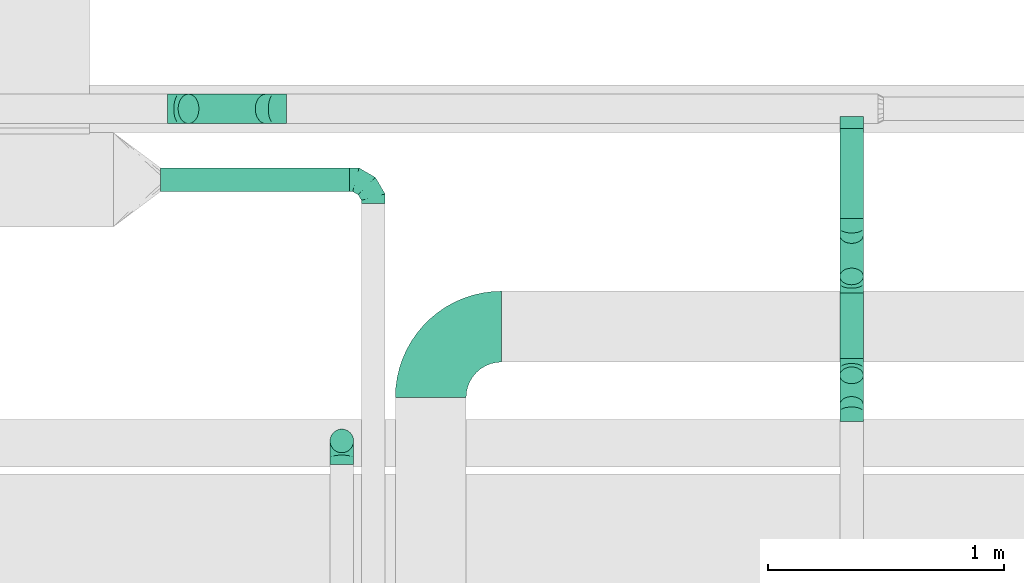
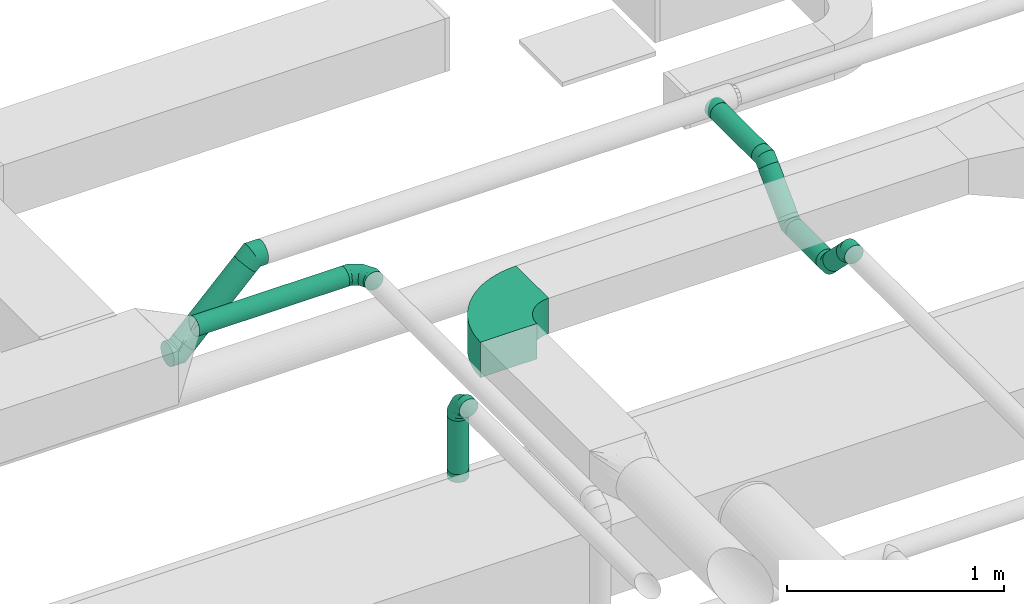
# One storey, part 38 of 60: 11 flow fittings, 7 flow segments.
"""IFC2X3 building model written with IfcOpenShell, lengths in millimetres."""

from ifc_helpers import new_model, entity, si_unit, converted_unit, derived_unit, direction, frame, frame_2d, origin, origin_2d_with_axis, place, context, subcontext, project, spatial, polyline, circle_curve, parameter, trimmed, segment, composite_curve, circle, outline, extrude, faceted_brep, source, transform, mapped, material, type_object, type_shapes, element, save


model = new_model("IFC2X3")

# Units and contexts
model_context = context("Model", 3, precision=0.01, world=origin(), true_north=direction((6.12303176911189e-17, 1.0)))
body_context = subcontext(model_context, "Body", "Model", "MODEL_VIEW")
ifc_project = project(units=[si_unit("LENGTHUNIT", "METRE", prefix="MILLI"), si_unit("AREAUNIT", "SQUARE_METRE"), si_unit("VOLUMEUNIT", "CUBIC_METRE"), converted_unit("PLANEANGLEUNIT", "DEGREE", entity("IfcRatioMeasure", 0.0174532925199433), si_unit("PLANEANGLEUNIT", "RADIAN"), dimensions=[0, 0, 0, 0, 0, 0, 0]), si_unit("MASSUNIT", "GRAM", prefix="KILO"), derived_unit("MASSDENSITYUNIT", [(si_unit("MASSUNIT", "GRAM", prefix="KILO"), 1), (si_unit("LENGTHUNIT", "METRE"), -3)]), derived_unit("MOMENTOFINERTIAUNIT", [(si_unit("LENGTHUNIT", "METRE"), 4)]), si_unit("TIMEUNIT", "SECOND"), si_unit("FREQUENCYUNIT", "HERTZ"), si_unit("THERMODYNAMICTEMPERATUREUNIT", "DEGREE_CELSIUS"), derived_unit("THERMALTRANSMITTANCEUNIT", [(si_unit("MASSUNIT", "GRAM", prefix="KILO"), 1), (si_unit("THERMODYNAMICTEMPERATUREUNIT", "KELVIN"), -1), (si_unit("TIMEUNIT", "SECOND"), -3)]), derived_unit("VOLUMETRICFLOWRATEUNIT", [(si_unit("LENGTHUNIT", "METRE"), 3), (si_unit("TIMEUNIT", "SECOND"), -1)]), derived_unit("MASSFLOWRATEUNIT", [(si_unit("MASSUNIT", "GRAM", prefix="KILO"), 1), (si_unit("TIMEUNIT", "SECOND"), -1)]), derived_unit("ROTATIONALFREQUENCYUNIT", [(si_unit("TIMEUNIT", "SECOND"), -1)]), si_unit("ELECTRICCURRENTUNIT", "AMPERE"), si_unit("ELECTRICVOLTAGEUNIT", "VOLT"), si_unit("POWERUNIT", "WATT"), si_unit("FORCEUNIT", "NEWTON", prefix="KILO"), si_unit("ILLUMINANCEUNIT", "LUX"), si_unit("LUMINOUSFLUXUNIT", "LUMEN"), si_unit("LUMINOUSINTENSITYUNIT", "CANDELA"), derived_unit("USERDEFINED", [(si_unit("MASSUNIT", "GRAM", prefix="KILO"), -1), (si_unit("LENGTHUNIT", "METRE"), -2), (si_unit("TIMEUNIT", "SECOND"), 3), (si_unit("LUMINOUSFLUXUNIT", "LUMEN"), 1)]), derived_unit("LINEARVELOCITYUNIT", [(si_unit("LENGTHUNIT", "METRE"), 1), (si_unit("TIMEUNIT", "SECOND"), -1)]), si_unit("PRESSUREUNIT", "PASCAL"), derived_unit("USERDEFINED", [(si_unit("LENGTHUNIT", "METRE"), -2), (si_unit("MASSUNIT", "GRAM", prefix="KILO"), 1), (si_unit("TIMEUNIT", "SECOND"), -2)]), derived_unit("LINEARFORCEUNIT", [(si_unit("MASSUNIT", "GRAM", prefix="KILO"), 1), (si_unit("LENGTHUNIT", "METRE"), 1), (si_unit("TIMEUNIT", "SECOND"), -2), (si_unit("LENGTHUNIT", "METRE"), -1)]), derived_unit("PLANARFORCEUNIT", [(si_unit("MASSUNIT", "GRAM", prefix="KILO"), 1), (si_unit("LENGTHUNIT", "METRE"), 1), (si_unit("TIMEUNIT", "SECOND"), -2), (si_unit("LENGTHUNIT", "METRE"), -2)])], contexts=[model_context])

# Site, building, storey
site_placement = place(None, origin())
site = spatial("IfcSite", under=ifc_project, at=site_placement, CompositionType="ELEMENT")
building_placement = place(site_placement, origin())
building = spatial("IfcBuilding", under=site, at=building_placement, CompositionType="ELEMENT")
storey_placement = place(building_placement, frame((0.0, 0.0, 19800.0)))
storey = spatial("IfcBuildingStorey", under=building, at=storey_placement, CompositionType="ELEMENT", Elevation=19800.0)

# Flow segments
duct_segment_type = type_object("IfcDuctSegmentType", PredefinedType="NOTDEFINED")
flow_segment_1_placement = place(storey_placement, frame((49421.97, 9933.75, 3548.4)))
element("IfcFlowSegment", 1, at=flow_segment_1_placement, inside=storey, type_object=duct_segment_type, context=body_context, shape_type="SweptSolid", body=[
    extrude(circle(Radius=50.0, at=origin_2d_with_axis()), frame((0.0, 51.6, 51.6), z_axis=(1.0, 0.0, 0.0), x_axis=(0.0, 1.0, 0.0)), (0.0, 0.0, 1.0), 800.000000000026),
])
flow_segment_2_placement = place(storey_placement, frame((50137.46, 8828.41, 3199.5)))
element("IfcFlowSegment", 2, at=flow_segment_2_placement, inside=storey, type_object=duct_segment_type, context=body_context, shape_type="SweptSolid", body=[
    extrude(circle(Radius=50.0, at=origin_2d_with_axis()), frame((51.6, 51.6, 0.0), z_axis=(0.0, 0.0, 1.0), x_axis=(-1.0, 0.0, 0.0)), (0.0, 0.0, 1.0), 300.501256289336),
])
flow_segment_3_placement = place(storey_placement, frame((52295.4, 8995.51, 3408.49)))
element("IfcFlowSegment", 3, at=flow_segment_3_placement, inside=storey, type_object=duct_segment_type, context=body_context, shape_type="SweptSolid", body=[
    extrude(circle(Radius=50.0, at=origin_2d_with_axis()), frame((51.6, 162.22, 36.95), z_axis=(0.0, -0.707106781186556, 0.707106781186539), x_axis=(1.0, 0.0, 0.0)), (0.0, 0.0, 1.0), 177.157287525386),
])
flow_segment_4_placement = place(storey_placement, frame((52295.4, 9228.44, 3364.56)))
element("IfcFlowSegment", 4, at=flow_segment_4_placement, inside=storey, type_object=duct_segment_type, context=body_context, shape_type="SweptSolid", body=[
    extrude(circle(Radius=50.0, at=origin_2d_with_axis()), frame((51.6, 0.0, 51.6), z_axis=(0.0, 1.0, 0.0), x_axis=(1.0, 0.0, 0.0)), (0.0, 0.0, 1.0), 277.15728752539),
])
flow_segment_5_placement = place(storey_placement, frame((52295.4, 9539.36, 3408.49)))
element("IfcFlowSegment", 5, at=flow_segment_5_placement, inside=storey, type_object=duct_segment_type, context=body_context, shape_type="SweptSolid", body=[
    extrude(circle(Radius=50.0, at=origin_2d_with_axis()), frame((51.6, 36.95, 36.95), z_axis=(0.0, 0.707106781186548, 0.707106781186548), x_axis=(1.0, 0.0, 0.0)), (0.0, 0.0, 1.0), 247.867965644035),
])
flow_segment_6_placement = place(storey_placement, frame((52295.4, 9822.29, 3598.4)))
element("IfcFlowSegment", 6, at=flow_segment_6_placement, inside=storey, type_object=duct_segment_type, context=body_context, shape_type="SweptSolid", body=[
    extrude(circle(Radius=50.0, at=origin_2d_with_axis()), frame((51.6, 0.0, 51.6), z_axis=(0.0, 1.0, 0.0), x_axis=(1.0, 0.0, 0.0)), (0.0, 0.0, 1.0), 380.827268914699),
])
flow_segment_7_placement = place(storey_placement, frame((49494.53, 10221.52, 3240.82)))
element("IfcFlowSegment", 7, at=flow_segment_7_placement, inside=storey, type_object=duct_segment_type, context=body_context, shape_type="SweptSolid", body=[
    extrude(circle(Radius=62.5, at=origin_2d_with_axis()), frame((45.79, 64.1, 45.79), z_axis=(0.707106781186548, 0.0, 0.707106781186548), x_axis=(0.0, 1.0, 0.0)), (0.0, 0.0, 1.0), 462.132034355944),
])

# Flow fittings
ifc_material = material()
duct_fitting_type_1 = type_object("IfcDuctFittingType", PredefinedType="NOTDEFINED", material=ifc_material)
shared_shape_1 = source(origin(), body_context, "Body", "Brep", [
    faceted_brep([(-100.0, 0.0, -50.0), (-100.0, -12.94, -48.3), (-100.0, -25.0, -43.3), (-100.0, -35.36, -35.36), (-100.0, -43.3, -25.0), (-100.0, -48.3, -12.94), (-100.0, -50.0, 0.0), (-100.0, -48.3, 12.94), (-100.0, -43.3, 25.0), (-100.0, -35.36, 35.36), (-100.0, -25.0, 43.3), (-100.0, -12.94, 48.3), (-100.0, 0.0, 50.0), (-100.0, 12.94, 48.3), (-100.0, 25.0, 43.3), (-100.0, 35.36, 35.36), (-100.0, 43.3, 25.0), (-100.0, 48.3, 12.94), (-100.0, 50.0, 0.0), (-100.0, 48.3, -12.94), (-100.0, 43.3, -25.0), (-100.0, 35.36, -35.36), (-100.0, 25.0, -43.3), (-100.0, 12.94, -48.3), (-76.67, 12.94, 48.3), (-79.9, 25.0, 43.3), (-73.21, 0.0, 50.0), (-82.68, 35.36, 35.36), (-86.15, 48.3, 12.94), (-86.6, 50.0, 0.0), (-84.81, 43.3, 25.0), (-84.81, 43.3, -25.0), (-82.68, 35.36, -35.36), (-86.15, 48.3, -12.94), (-76.67, 12.94, -48.3), (-73.21, 0.0, -50.0), (-79.9, 25.0, -43.3), (-69.74, -12.94, -48.3), (-66.51, -25.0, -43.3), (-63.73, -35.36, -35.36), (-61.6, -43.3, -25.0), (-60.26, -48.3, -12.94), (-59.81, -50.0, 0.0), (-60.26, -48.3, 12.94), (-61.6, -43.3, 25.0), (-63.73, -35.36, 35.36), (-66.51, -25.0, 43.3), (-69.74, -12.94, 48.3), (-36.27, 36.27, 48.3), (-45.1, 45.1, 43.3), (-26.79, 26.79, 50.0), (-52.68, 52.68, 35.36), (-58.49, 58.49, 25.0), (-62.15, 62.15, 12.94), (-63.4, 63.4, 0.0), (-62.15, 62.15, -12.94), (-58.49, 58.49, -25.0), (-52.68, 52.68, -35.36), (-36.27, 36.27, -48.3), (-26.79, 26.79, -50.0), (-45.1, 45.1, -43.3), (-17.32, 17.32, -48.3), (-8.49, 8.49, -43.3), (-0.91, 0.91, -35.36), (4.9, -4.9, -25.0), (8.56, -8.56, -12.94), (9.81, -9.81, 0.0), (8.56, -8.56, 12.94), (4.9, -4.9, 25.0), (-0.91, 0.91, 35.36), (-8.49, 8.49, 43.3), (-17.32, 17.32, 48.3), (-12.94, 76.67, 48.3), (-25.0, 79.9, 43.3), (0.0, 73.21, 50.0), (-35.36, 82.68, 35.36), (-43.3, 84.81, 25.0), (-48.3, 86.15, 12.94), (-50.0, 86.6, 0.0), (-48.3, 86.15, -12.94), (-43.3, 84.81, -25.0), (-35.36, 82.68, -35.36), (-12.94, 76.67, -48.3), (0.0, 73.21, -50.0), (-25.0, 79.9, -43.3), (12.94, 69.74, -48.3), (25.0, 66.51, -43.3), (35.36, 63.73, -35.36), (43.3, 61.6, -25.0), (48.3, 60.26, -12.94), (50.0, 59.81, 0.0), (48.3, 60.26, 12.94), (43.3, 61.6, 25.0), (35.36, 63.73, 35.36), (25.0, 66.51, 43.3), (12.94, 69.74, 48.3), (-12.94, 100.0, -48.3), (-25.0, 100.0, -43.3), (-35.36, 100.0, -35.36), (-43.3, 100.0, -25.0), (-48.3, 100.0, -12.94), (-50.0, 100.0, 0.0), (-48.3, 100.0, 12.94), (-43.3, 100.0, 25.0), (-35.36, 100.0, 35.36), (-25.0, 100.0, 43.3), (-12.94, 100.0, 48.3), (0.0, 100.0, 50.0), (12.94, 100.0, 48.3), (25.0, 100.0, 43.3), (35.36, 100.0, 35.36), (43.3, 100.0, 25.0), (48.3, 100.0, 12.94), (50.0, 100.0, 0.0), (48.3, 100.0, -12.94), (43.3, 100.0, -25.0), (35.36, 100.0, -35.36), (25.0, 100.0, -43.3), (12.94, 100.0, -48.3), (0.0, 100.0, -50.0)], [[[0, 1, 2, 3, 4, 5, 6, 7, 8, 9, 10, 11, 12, 13, 14, 15, 16, 17, 18, 19, 20, 21, 22, 23]], [[24, 25, 14, 13]], [[26, 24, 13, 12]], [[14, 25, 27, 15]], [[28, 29, 18, 17]], [[30, 28, 17, 16]], [[15, 27, 30, 16]], [[20, 31, 32, 21]], [[33, 31, 20, 19]], [[18, 29, 33, 19]], [[34, 35, 0, 23]], [[36, 34, 23, 22]], [[32, 36, 22, 21]], [[2, 1, 37, 38]], [[3, 2, 38, 39]], [[0, 35, 37, 1]], [[5, 4, 40, 41]], [[6, 5, 41, 42]], [[3, 39, 40, 4]], [[6, 42, 43, 7]], [[7, 43, 44, 8]], [[8, 44, 45, 9]], [[10, 46, 47, 11]], [[11, 47, 26, 12]], [[10, 9, 45, 46]], [[48, 49, 25, 24]], [[50, 48, 24, 26]], [[27, 25, 49, 51]], [[52, 53, 28, 30]], [[51, 52, 30, 27]], [[29, 28, 53, 54]], [[55, 56, 31, 33]], [[54, 55, 33, 29]], [[57, 32, 31, 56]], [[58, 59, 35, 34]], [[60, 58, 34, 36]], [[57, 60, 36, 32]], [[37, 35, 59, 61]], [[38, 37, 61, 62]], [[39, 38, 62, 63]], [[41, 40, 64, 65]], [[42, 41, 65, 66]], [[63, 64, 40, 39]], [[43, 42, 66, 67]], [[44, 43, 67, 68]], [[68, 69, 45, 44]], [[46, 45, 69, 70]], [[47, 46, 70, 71]], [[26, 47, 71, 50]], [[72, 73, 49, 48]], [[74, 72, 48, 50]], [[51, 49, 73, 75]], [[76, 77, 53, 52]], [[75, 76, 52, 51]], [[54, 53, 77, 78]], [[79, 80, 56, 55]], [[78, 79, 55, 54]], [[81, 57, 56, 80]], [[82, 83, 59, 58]], [[84, 82, 58, 60]], [[81, 84, 60, 57]], [[61, 59, 83, 85]], [[62, 61, 85, 86]], [[63, 62, 86, 87]], [[65, 64, 88, 89]], [[66, 65, 89, 90]], [[87, 88, 64, 63]], [[67, 66, 90, 91]], [[68, 67, 91, 92]], [[92, 93, 69, 68]], [[70, 69, 93, 94]], [[71, 70, 94, 95]], [[50, 71, 95, 74]], [[96, 97, 98, 99, 100, 101, 102, 103, 104, 105, 106, 107, 108, 109, 110, 111, 112, 113, 114, 115, 116, 117, 118, 119]], [[72, 74, 107, 106]], [[73, 72, 106, 105]], [[75, 73, 105, 104]], [[77, 76, 103, 102]], [[78, 77, 102, 101]], [[75, 104, 103, 76]], [[78, 101, 100, 79]], [[79, 100, 99, 80]], [[80, 99, 98, 81]], [[96, 119, 83, 82]], [[97, 96, 82, 84]], [[84, 81, 98, 97]], [[83, 119, 118, 85]], [[85, 118, 117, 86]], [[86, 117, 116, 87]], [[88, 115, 114, 89]], [[89, 114, 113, 90]], [[87, 116, 115, 88]], [[91, 90, 113, 112]], [[92, 91, 112, 111]], [[93, 92, 111, 110]], [[95, 94, 109, 108]], [[74, 95, 108, 107]], [[110, 109, 94, 93]]]),
])
type_shapes(duct_fitting_type_1, [shared_shape_1])
for number, where, z_axis, x_axis in (
    (8, (50321.97, 9985.34, 3600.0), (0.0, 0.0, 1.0), (0.0, 1.0, 0.0)),
    (9, (50189.05, 8880.01, 3600.0), (1.0, 0.0, 0.0), (0.0, 0.0, 1.0)),
):
    element("IfcFlowFitting", number, at=place(storey_placement, frame(where, z_axis=z_axis, x_axis=x_axis)), inside=storey, type_object=duct_fitting_type_1, material=ifc_material, context=body_context, shape_type="MappedRepresentation", body=[
        mapped(shared_shape_1, transform((0.0, 0.0, 0.0), scale=1.0)),
    ])
duct_fitting_type_2 = type_object("IfcDuctFittingType", PredefinedType="NOTDEFINED", material=ifc_material)
shared_shape_2 = source(origin(), body_context, "Body", "Brep", [
    faceted_brep([(-51.78, 0.0, -62.5), (-51.78, -16.18, -60.37), (-51.78, -31.25, -54.13), (-51.78, -44.19, -44.19), (-51.78, -54.13, -31.25), (-51.78, -60.37, -16.18), (-51.78, -62.5, 0.0), (-51.78, -60.37, 16.18), (-51.78, -54.13, 31.25), (-51.78, -44.19, 44.19), (-51.78, -31.25, 54.13), (-51.78, -16.18, 60.37), (-51.78, 0.0, 62.5), (-51.78, 16.18, 60.37), (-51.78, 31.25, 54.13), (-51.78, 44.19, 44.19), (-51.78, 54.13, 31.25), (-51.78, 60.37, 16.18), (-51.78, 62.5, 0.0), (-51.78, 60.37, -16.18), (-51.78, 54.13, -31.25), (-51.78, 44.19, -44.19), (-51.78, 31.25, -54.13), (-51.78, 16.18, -60.37), (-6.7, 16.18, 60.37), (-12.94, 31.25, 54.13), (0.0, 0.0, 62.5), (-18.31, 44.19, 44.19), (-22.42, 54.13, 31.25), (-25.01, 60.37, 16.18), (-25.89, 62.5, 0.0), (-25.01, 60.37, -16.18), (-22.42, 54.13, -31.25), (-18.31, 44.19, -44.19), (-6.7, 16.18, -60.37), (0.0, 0.0, -62.5), (-12.94, 31.25, -54.13), (6.7, -16.18, -60.37), (12.94, -31.25, -54.13), (18.31, -44.19, -44.19), (22.42, -54.13, -31.25), (25.01, -60.37, -16.18), (25.89, -62.5, 0.0), (25.01, -60.37, 16.18), (22.42, -54.13, 31.25), (18.31, -44.19, 44.19), (12.94, -31.25, 54.13), (6.7, -16.18, 60.37), (25.17, 48.05, 60.37), (14.51, 58.71, 54.13), (36.61, 36.61, 62.5), (5.36, 67.86, 44.19), (-1.66, 74.88, 31.25), (-6.08, 79.3, 16.18), (-7.58, 80.81, 0.0), (-6.08, 79.3, -16.18), (-1.66, 74.88, -31.25), (5.36, 67.86, -44.19), (14.51, 58.71, -54.13), (25.17, 48.05, -60.37), (36.61, 36.61, -62.5), (48.05, 25.17, -60.37), (58.71, 14.51, -54.13), (67.86, 5.36, -44.19), (74.88, -1.66, -31.25), (79.3, -6.08, -16.18), (80.81, -7.58, 0.0), (79.3, -6.08, 16.18), (74.88, -1.66, 31.25), (67.86, 5.36, 44.19), (58.71, 14.51, 54.13), (48.05, 25.17, 60.37)], [[[0, 1, 2, 3, 4, 5, 6, 7, 8, 9, 10, 11, 12, 13, 14, 15, 16, 17, 18, 19, 20, 21, 22, 23]], [[24, 25, 14, 13]], [[26, 24, 13, 12]], [[27, 15, 14, 25]], [[28, 29, 17, 16]], [[28, 16, 15, 27]], [[30, 18, 17, 29]], [[31, 32, 20, 19]], [[30, 31, 19, 18]], [[21, 20, 32, 33]], [[34, 35, 0, 23]], [[36, 34, 23, 22]], [[33, 36, 22, 21]], [[1, 0, 35, 37]], [[2, 1, 37, 38]], [[38, 39, 3, 2]], [[5, 4, 40, 41]], [[6, 5, 41, 42]], [[39, 40, 4, 3]], [[6, 42, 43, 7]], [[7, 43, 44, 8]], [[8, 44, 45, 9]], [[9, 45, 46, 10]], [[10, 46, 47, 11]], [[26, 12, 11, 47]], [[48, 49, 25, 24]], [[50, 48, 24, 26]], [[27, 25, 49, 51]], [[29, 28, 52, 53]], [[30, 29, 53, 54]], [[51, 52, 28, 27]], [[30, 54, 55, 31]], [[31, 55, 56, 32]], [[57, 33, 32, 56]], [[36, 58, 59, 34]], [[34, 59, 60, 35]], [[58, 36, 33, 57]], [[35, 60, 61, 37]], [[37, 61, 62, 38]], [[63, 39, 38, 62]], [[40, 64, 65, 41]], [[41, 65, 66, 42]], [[64, 40, 39, 63]], [[43, 42, 66, 67]], [[44, 43, 67, 68]], [[68, 69, 45, 44]], [[47, 46, 70, 71]], [[26, 47, 71, 50]], [[69, 70, 46, 45]], [[59, 58, 57, 56, 55, 54, 53, 52, 51, 49, 48, 50, 71, 70, 69, 68, 67, 66, 65, 64, 63, 62, 61, 60]]]),
])
type_shapes(duct_fitting_type_2, [shared_shape_2])
for number, where, z_axis, x_axis in (
    (10, (49903.7, 10285.62, 3650.0), (0.0, -1.0, 0.0), (-1.0, 0.0, 0.0)),
    (11, (49503.7, 10285.62, 3250.0), (0.0, 1.0, 0.0), (-0.70710678118653, 0.0, -0.707106781186565)),
):
    element("IfcFlowFitting", number, at=place(storey_placement, frame(where, z_axis=z_axis, x_axis=x_axis)), inside=storey, type_object=duct_fitting_type_2, material=ifc_material, context=body_context, shape_type="MappedRepresentation", body=[
        mapped(shared_shape_2, transform((0.0, 0.0, 0.0), scale=1.0)),
    ])
duct_fitting_type_3 = type_object("IfcDuctFittingType", PredefinedType="NOTDEFINED", material=ifc_material)
shared_shape_3 = source(origin(), body_context, "Body", "Brep", [
    faceted_brep([(-41.42, 0.0, -50.0), (-41.42, -12.94, -48.3), (-41.42, -25.0, -43.3), (-41.42, -35.36, -35.36), (-41.42, -43.3, -25.0), (-41.42, -48.3, -12.94), (-41.42, -50.0, 0.0), (-41.42, -48.3, 12.94), (-41.42, -43.3, 25.0), (-41.42, -35.36, 35.36), (-41.42, -25.0, 43.3), (-41.42, -12.94, 48.3), (-41.42, 0.0, 50.0), (-41.42, 12.94, 48.3), (-41.42, 25.0, 43.3), (-41.42, 35.36, 35.36), (-41.42, 43.3, 25.0), (-41.42, 48.3, 12.94), (-41.42, 50.0, 0.0), (-41.42, 48.3, -12.94), (-41.42, 43.3, -25.0), (-41.42, 35.36, -35.36), (-41.42, 25.0, -43.3), (-41.42, 12.94, -48.3), (-5.36, 12.94, 48.3), (-10.36, 25.0, 43.3), (0.0, 0.0, 50.0), (-14.64, 35.36, 35.36), (-20.0, 48.3, 12.94), (-20.71, 50.0, 0.0), (-17.94, 43.3, 25.0), (-17.94, 43.3, -25.0), (-14.64, 35.36, -35.36), (-20.0, 48.3, -12.94), (-5.36, 12.94, -48.3), (0.0, 0.0, -50.0), (-10.36, 25.0, -43.3), (5.36, -12.94, -48.3), (10.36, -25.0, -43.3), (14.64, -35.36, -35.36), (17.94, -43.3, -25.0), (20.0, -48.3, -12.94), (20.71, -50.0, 0.0), (20.0, -48.3, 12.94), (17.94, -43.3, 25.0), (14.64, -35.36, 35.36), (10.36, -25.0, 43.3), (5.36, -12.94, 48.3), (29.29, 29.29, 50.0), (20.14, 38.44, 48.3), (11.61, 46.97, 43.3), (4.29, 54.29, 35.36), (-1.33, 59.91, 25.0), (-4.86, 63.44, 12.94), (-6.07, 64.64, 0.0), (-4.86, 63.44, -12.94), (-1.33, 59.91, -25.0), (4.29, 54.29, -35.36), (11.61, 46.97, -43.3), (20.14, 38.44, -48.3), (29.29, 29.29, -50.0), (38.44, 20.14, -48.3), (46.97, 11.61, -43.3), (54.29, 4.29, -35.36), (59.91, -1.33, -25.0), (63.44, -4.86, -12.94), (64.64, -6.07, 0.0), (63.44, -4.86, 12.94), (59.91, -1.33, 25.0), (54.29, 4.29, 35.36), (46.97, 11.61, 43.3), (38.44, 20.14, 48.3)], [[[0, 1, 2, 3, 4, 5, 6, 7, 8, 9, 10, 11, 12, 13, 14, 15, 16, 17, 18, 19, 20, 21, 22, 23]], [[24, 25, 14, 13]], [[26, 24, 13, 12]], [[14, 25, 27, 15]], [[28, 29, 18, 17]], [[30, 28, 17, 16]], [[16, 15, 27, 30]], [[20, 31, 32, 21]], [[33, 31, 20, 19]], [[18, 29, 33, 19]], [[34, 35, 0, 23]], [[36, 34, 23, 22]], [[32, 36, 22, 21]], [[1, 0, 35, 37]], [[2, 1, 37, 38]], [[38, 39, 3, 2]], [[5, 4, 40, 41]], [[6, 5, 41, 42]], [[39, 40, 4, 3]], [[6, 42, 43, 7]], [[7, 43, 44, 8]], [[8, 44, 45, 9]], [[9, 45, 46, 10]], [[10, 46, 47, 11]], [[26, 12, 11, 47]], [[24, 26, 48, 49]], [[25, 24, 49, 50]], [[27, 25, 50, 51]], [[28, 30, 52, 53]], [[29, 28, 53, 54]], [[27, 51, 52, 30]], [[29, 54, 55, 33]], [[33, 55, 56, 31]], [[31, 56, 57, 32]], [[36, 58, 59, 34]], [[34, 59, 60, 35]], [[36, 32, 57, 58]], [[61, 62, 38, 37]], [[60, 61, 37, 35]], [[63, 39, 38, 62]], [[40, 64, 65, 41]], [[41, 65, 66, 42]], [[64, 40, 39, 63]], [[43, 42, 66, 67]], [[44, 43, 67, 68]], [[68, 69, 45, 44]], [[47, 46, 70, 71]], [[26, 47, 71, 48]], [[69, 70, 46, 45]], [[59, 58, 57, 56, 55, 54, 53, 52, 51, 50, 49, 48, 71, 70, 69, 68, 67, 66, 65, 64, 63, 62, 61, 60]]]),
])
type_shapes(duct_fitting_type_3, [shared_shape_3])
for number, where, z_axis, x_axis in (
    (12, (52347.0, 9003.18, 3600.0), (-1.0, 0.0, 0.0), (0.0, 1.0, 0.0)),
    (13, (52347.0, 9187.02, 3416.15), (1.0, 0.0, 0.0), (0.0, 0.707106781186525, -0.70710678118657)),
    (14, (52347.0, 9547.02, 3416.15), (1.0, 0.0, 0.0), (0.0, 1.0, 0.0)),
    (15, (52347.0, 9780.87, 3650.0), (-1.0, 0.0, 0.0), (0.0, 0.707106781186502, 0.707106781186593)),
):
    element("IfcFlowFitting", number, at=place(storey_placement, frame(where, z_axis=z_axis, x_axis=x_axis)), inside=storey, type_object=duct_fitting_type_3, material=ifc_material, context=body_context, shape_type="MappedRepresentation", body=[
        mapped(shared_shape_3, transform((0.0, 0.0, 0.0), scale=1.0)),
    ])
duct_fitting_type_4 = type_object("IfcDuctFittingType", PredefinedType="NOTDEFINED", material=ifc_material)
shared_shape_4 = source(origin(), body_context, "Body", "Brep", [
    faceted_brep([(20.0, 12.94, -48.3), (20.0, 25.0, -43.3), (20.0, 35.36, -35.36), (20.0, 43.3, -25.0), (20.0, 48.3, -12.94), (20.0, 50.0, 0.0), (20.0, 48.3, 12.94), (20.0, 43.3, 25.0), (20.0, 35.36, 35.36), (20.0, 25.0, 43.3), (20.0, 12.94, 48.3), (20.0, 0.0, 50.0), (20.0, -12.94, 48.3), (20.0, -25.0, 43.3), (20.0, -35.36, 35.36), (20.0, -43.3, 25.0), (20.0, -48.3, 12.94), (20.0, -50.0, 0.0), (20.0, -48.3, -12.94), (20.0, -43.3, -25.0), (20.0, -35.36, -35.36), (20.0, -25.0, -43.3), (20.0, -12.94, -48.3), (20.0, 0.0, -50.0), (0.0, 0.0, 50.0), (0.0, 12.94, 48.3), (-31.1, 12.94, 48.3), (-31.1, 0.0, 50.0), (0.0, 25.0, 43.3), (-31.1, 25.0, 43.3), (0.0, 35.36, 35.36), (-31.1, 35.36, 35.36), (0.0, 43.3, 25.0), (0.0, 48.3, 12.94), (-31.1, 48.3, 12.94), (-31.1, 43.3, 25.0), (0.0, 50.0, 0.0), (-31.1, 50.0, 0.0), (0.0, 48.3, -12.94), (-31.1, 48.3, -12.94), (0.0, 43.3, -25.0), (-31.1, 43.3, -25.0), (0.0, 35.36, -35.36), (-31.1, 35.36, -35.36), (0.0, 25.0, -43.3), (0.0, 12.94, -48.3), (-31.1, 12.94, -48.3), (-31.1, 25.0, -43.3), (0.0, 0.0, -50.0), (-31.1, 0.0, -50.0), (0.0, -12.94, -48.3), (-31.1, -12.94, -48.3), (0.0, -25.0, -43.3), (-31.1, -25.0, -43.3), (0.0, -35.36, -35.36), (-31.1, -35.36, -35.36), (0.0, -43.3, -25.0), (0.0, -48.3, -12.94), (-31.1, -48.3, -12.94), (-31.1, -43.3, -25.0), (0.0, -50.0, 0.0), (-31.1, -50.0, 0.0), (0.0, -48.3, 12.94), (-31.1, -48.3, 12.94), (0.0, -43.3, 25.0), (-31.1, -43.3, 25.0), (0.0, -35.36, 35.36), (-31.1, -35.36, 35.36), (0.0, -25.0, 43.3), (0.0, -12.94, 48.3), (-31.1, -12.94, 48.3), (-31.1, -25.0, 43.3)], [[[0, 1, 2, 3, 4, 5, 6, 7, 8, 9, 10, 11, 12, 13, 14, 15, 16, 17, 18, 19, 20, 21, 22, 23]], [[24, 11, 10, 25, 26, 27]], [[25, 10, 9, 28, 29, 26]], [[28, 9, 8, 30, 31, 29]], [[32, 7, 6, 33, 34, 35]], [[33, 6, 5, 36, 37, 34]], [[30, 8, 7, 32, 35, 31]], [[36, 5, 4, 38, 39, 37]], [[38, 4, 3, 40, 41, 39]], [[40, 3, 2, 42, 43, 41]], [[44, 1, 0, 45, 46, 47]], [[45, 0, 23, 48, 49, 46]], [[42, 2, 1, 44, 47, 43]], [[48, 23, 22, 50, 51, 49]], [[50, 22, 21, 52, 53, 51]], [[52, 21, 20, 54, 55, 53]], [[56, 19, 18, 57, 58, 59]], [[57, 18, 17, 60, 61, 58]], [[54, 20, 19, 56, 59, 55]], [[60, 17, 16, 62, 63, 61]], [[62, 16, 15, 64, 65, 63]], [[64, 15, 14, 66, 67, 65]], [[68, 13, 12, 69, 70, 71]], [[69, 12, 11, 24, 27, 70]], [[66, 14, 13, 68, 71, 67]], [[49, 51, 53, 55, 59, 58, 61, 63, 65, 67, 71, 70, 27, 26, 29, 31, 35, 34, 37, 39, 41, 43, 47, 46]]]),
])
type_shapes(duct_fitting_type_4, [shared_shape_4])
flow_fitting_1_placement = place(storey_placement, frame((52347.0, 10223.12, 3650.0), z_axis=(0.0, 0.0, -1.0), x_axis=(0.0, -1.0, 0.0)))
element("IfcFlowFitting", 16, at=flow_fitting_1_placement, inside=storey, type_object=duct_fitting_type_4, material=ifc_material, context=body_context, shape_type="MappedRepresentation", body=[
    mapped(shared_shape_4, transform((0.0, 0.0, 0.0), scale=1.0)),
])
duct_fitting_type_5 = type_object("IfcDuctFittingType", PredefinedType="NOTDEFINED", material=ifc_material)
shared_shape_5 = source(origin(), body_context, "Body", "Brep", [
    faceted_brep([(20.0, 12.94, -48.3), (20.0, 25.0, -43.3), (20.0, 35.36, -35.36), (20.0, 43.3, -25.0), (20.0, 48.3, -12.94), (20.0, 50.0, 0.0), (20.0, 48.3, 12.94), (20.0, 43.3, 25.0), (20.0, 35.36, 35.36), (20.0, 25.0, 43.3), (20.0, 12.94, 48.3), (20.0, 0.0, 50.0), (20.0, -12.94, 48.3), (20.0, -25.0, 43.3), (20.0, -35.36, 35.36), (20.0, -43.3, 25.0), (20.0, -48.3, 12.94), (20.0, -50.0, 0.0), (20.0, -48.3, -12.94), (20.0, -43.3, -25.0), (20.0, -35.36, -35.36), (20.0, -25.0, -43.3), (20.0, -12.94, -48.3), (20.0, 0.0, -50.0), (0.0, 0.0, 50.0), (0.0, 12.94, 48.3), (-25.59, 12.94, 48.3), (-25.59, 0.0, 50.0), (0.0, 25.0, 43.3), (-25.59, 25.0, 43.3), (0.0, 35.36, 35.36), (-25.59, 35.36, 35.36), (0.0, 43.3, 25.0), (0.0, 48.3, 12.94), (-25.59, 48.3, 12.94), (-25.59, 43.3, 25.0), (0.0, 50.0, 0.0), (-25.59, 50.0, 0.0), (0.0, 48.3, -12.94), (-25.59, 48.3, -12.94), (0.0, 43.3, -25.0), (-25.59, 43.3, -25.0), (0.0, 35.36, -35.36), (-25.59, 35.36, -35.36), (0.0, 25.0, -43.3), (0.0, 12.94, -48.3), (-25.59, 12.94, -48.3), (-25.59, 25.0, -43.3), (0.0, 0.0, -50.0), (-25.59, 0.0, -50.0), (0.0, -12.94, -48.3), (-25.59, -12.94, -48.3), (0.0, -25.0, -43.3), (-25.59, -25.0, -43.3), (0.0, -35.36, -35.36), (-25.59, -35.36, -35.36), (0.0, -43.3, -25.0), (0.0, -48.3, -12.94), (-25.59, -48.3, -12.94), (-25.59, -43.3, -25.0), (0.0, -50.0, 0.0), (-25.59, -50.0, 0.0), (0.0, -48.3, 12.94), (-25.59, -48.3, 12.94), (0.0, -43.3, 25.0), (-25.59, -43.3, 25.0), (0.0, -35.36, 35.36), (-25.59, -35.36, 35.36), (0.0, -25.0, 43.3), (0.0, -12.94, 48.3), (-25.59, -12.94, 48.3), (-25.59, -25.0, 43.3)], [[[0, 1, 2, 3, 4, 5, 6, 7, 8, 9, 10, 11, 12, 13, 14, 15, 16, 17, 18, 19, 20, 21, 22, 23]], [[24, 11, 10, 25, 26, 27]], [[25, 10, 9, 28, 29, 26]], [[28, 9, 8, 30, 31, 29]], [[32, 7, 6, 33, 34, 35]], [[33, 6, 5, 36, 37, 34]], [[30, 8, 7, 32, 35, 31]], [[36, 5, 4, 38, 39, 37]], [[38, 4, 3, 40, 41, 39]], [[40, 3, 2, 42, 43, 41]], [[44, 1, 0, 45, 46, 47]], [[45, 0, 23, 48, 49, 46]], [[42, 2, 1, 44, 47, 43]], [[48, 23, 22, 50, 51, 49]], [[50, 22, 21, 52, 53, 51]], [[52, 21, 20, 54, 55, 53]], [[56, 19, 18, 57, 58, 59]], [[57, 18, 17, 60, 61, 58]], [[54, 20, 19, 56, 59, 55]], [[60, 17, 16, 62, 63, 61]], [[62, 16, 15, 64, 65, 63]], [[64, 15, 14, 66, 67, 65]], [[68, 13, 12, 69, 70, 71]], [[69, 12, 11, 24, 27, 70]], [[66, 14, 13, 68, 71, 67]], [[49, 51, 53, 55, 59, 58, 61, 63, 65, 67, 71, 70, 27, 26, 29, 31, 35, 34, 37, 39, 41, 43, 47, 46]]]),
])
type_shapes(duct_fitting_type_5, [shared_shape_5])
flow_fitting_2_placement = place(storey_placement, frame((50189.05, 8880.01, 3179.5), z_axis=(0.0, 1.0, 0.0), x_axis=(0.0, 0.0, 1.0)))
element("IfcFlowFitting", 17, at=flow_fitting_2_placement, inside=storey, type_object=duct_fitting_type_5, material=ifc_material, context=body_context, shape_type="MappedRepresentation", body=[
    mapped(shared_shape_5, transform((0.0, 0.0, 0.0), scale=1.0)),
])
duct_fitting_type_6 = type_object("IfcDuctFittingType", PredefinedType="NOTDEFINED", material=ifc_material)
shared_shape_6 = source(origin(), body_context, "Body", "SweptSolid", [
    extrude(outline(composite_curve([segment(polyline([(-300.0, -150.0), (0.0, -150.0)]), True, "CONTINUOUS"), segment(trimmed(circle_curve(frame_2d((150.0, -150.0), x_axis=(0.0, 1.0)), 150.0), [parameter(0.0)], [parameter(90.0)], True, "PARAMETER"), False, "CONTINUOUS"), segment(polyline([(150.0, 0.0), (150.0, 300.0)]), True, "CONTINUOUS"), segment(trimmed(circle_curve(frame_2d((150.0, -150.0), x_axis=(0.0, 1.0)), 450.0), [parameter(0.0)], [parameter(90.0000000000001)], True, "PARAMETER"), True, "CONTINUOUS")], self_intersect=False)), frame((-150.0, 150.0, -100.0), z_axis=(0.0, 0.0, 1.0), x_axis=(-1.0, 0.0, 0.0)), (0.0, 0.0, 1.0), 200.0),
])
type_shapes(duct_fitting_type_6, [shared_shape_6])
flow_fitting_3_placement = place(storey_placement, frame((50565.38, 9363.95, 3620.0), z_axis=(0.0, 0.0, 1.0), x_axis=(-1.0, 0.0, 0.0)))
element("IfcFlowFitting", 18, at=flow_fitting_3_placement, inside=storey, type_object=duct_fitting_type_6, material=ifc_material, context=body_context, shape_type="MappedRepresentation", body=[
    mapped(shared_shape_6, transform((0.0, 0.0, 0.0), scale=1.0)),
])

save(model, "model.ifc")
